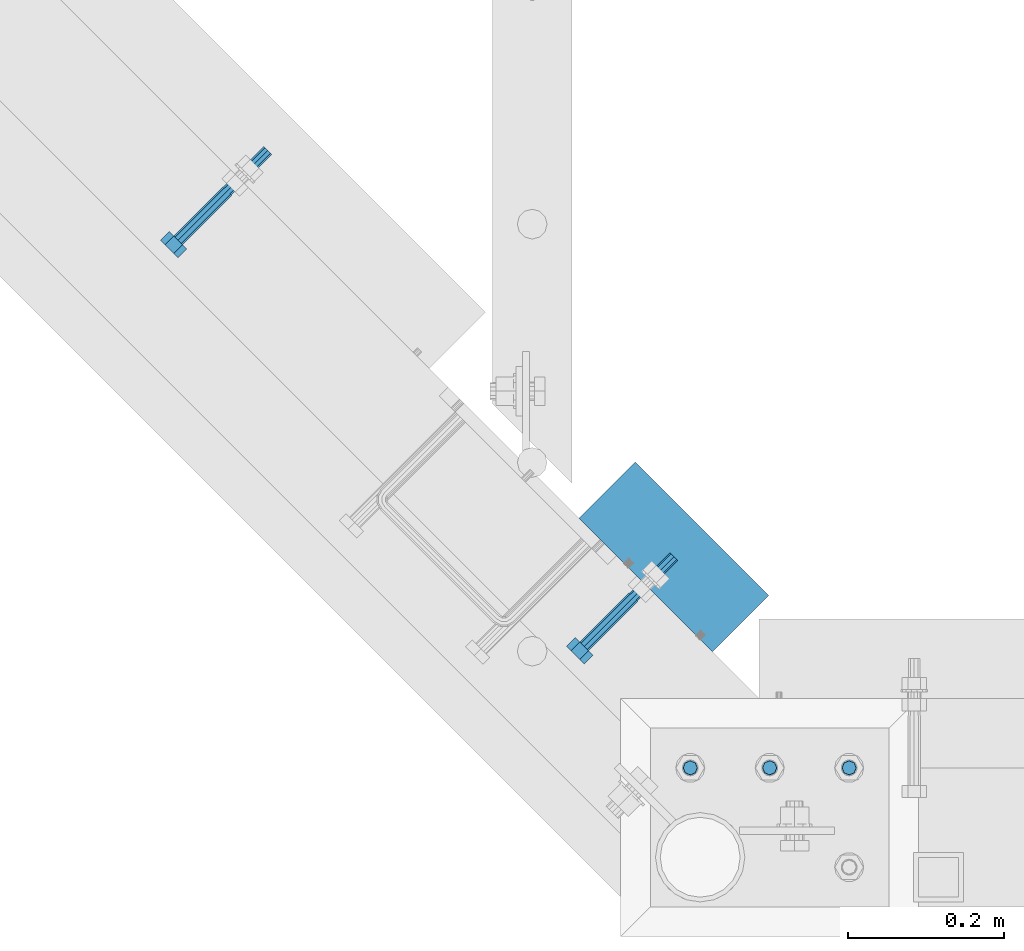
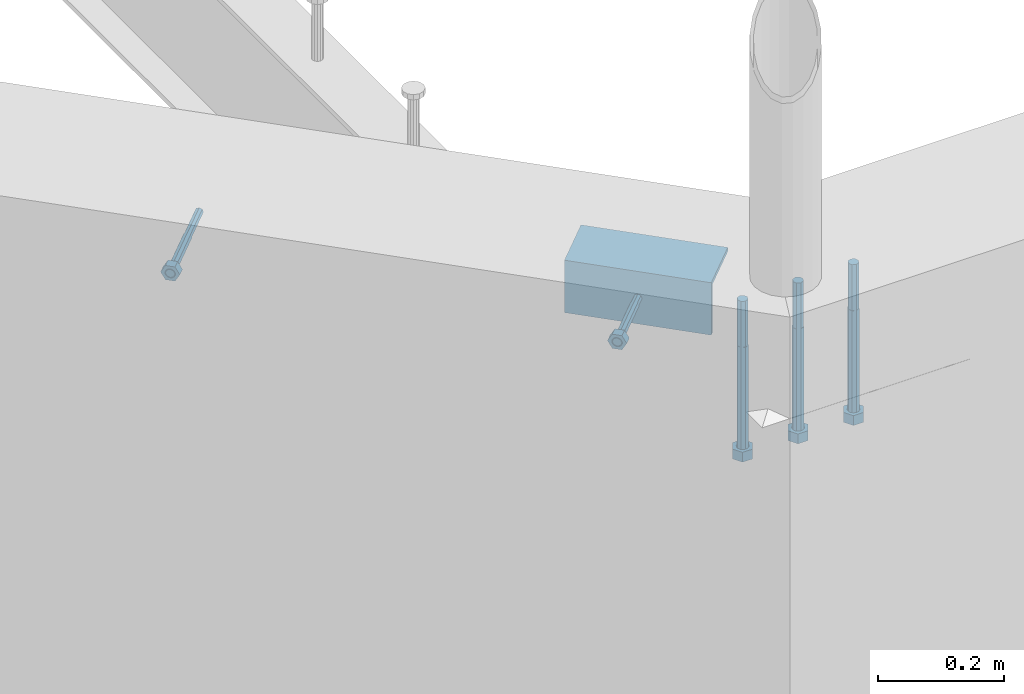
# One storey, part 382 of 975: 6 beams.
"""IFC2X3 building model written with IfcOpenShell, lengths in millimetres."""

from ifc_helpers import new_model, si_unit, frame, origin_with_axes, place, context, subcontext, project, spatial, faceted_brep, material, type_object, element, save


model = new_model("IFC2X3")

# Units and contexts
model_context = context("Model", 3, precision=1e-05, world=origin_with_axes())
body_context = subcontext(model_context, "Body", "Model", "MODEL_VIEW")
ifc_project = project(units=[si_unit("LENGTHUNIT", "METRE", prefix="MILLI"), si_unit("AREAUNIT", "SQUARE_METRE"), si_unit("VOLUMEUNIT", "CUBIC_METRE"), si_unit("MASSUNIT", "GRAM", prefix="KILO"), si_unit("TIMEUNIT", "SECOND"), si_unit("PLANEANGLEUNIT", "RADIAN"), si_unit("SOLIDANGLEUNIT", "STERADIAN"), si_unit("THERMODYNAMICTEMPERATUREUNIT", "DEGREE_CELSIUS"), si_unit("LUMINOUSINTENSITYUNIT", "LUMEN")], contexts=[model_context])

# Site, building, storey
site_placement = place(None, origin_with_axes())
site = spatial("IfcSite", under=ifc_project, at=site_placement, CompositionType="ELEMENT")
building_placement = place(site_placement, origin_with_axes())
building = spatial("IfcBuilding", under=site, at=building_placement, Name="Undefined", CompositionType="ELEMENT")
storey_placement = place(building_placement, origin_with_axes())
storey = spatial("IfcBuildingStorey", under=building, at=storey_placement, Name="Undefined", CompositionType="ELEMENT", Elevation=0.0)

# Beams
ifc_material_1 = material(Name="STEEL/F1554-36")
beam_type_1 = type_object("IfcBeamType", PredefinedType="NOTDEFINED")
beam_1_placement = place(storey_placement, frame((4419.9150254658, 434.231567113535, 3886.2), z_axis=(0.0, 0.0, -1.0), x_axis=(-0.707106781186548, -0.707106781186548, 0.0)))
element("IfcBeam", 1, at=beam_1_placement, inside=storey, type_object=beam_type_1, material=ifc_material_1, Name="HEADED_ANCHOR_BOLT", context=body_context, shape_type="Brep", body=[
    faceted_brep([(88.9000000184824, 7.94000001861696, -13.7499999799138), (88.8999999527368, 15.8800000758411, 2.00943759409711e-08), (104.774999952569, 15.8800001213949, 6.97191353538074e-08), (104.775000018315, 7.94000006417082, -13.7499999302891), (88.900000064019, -7.94000009583215, -13.7499999799147), (104.775000063852, -7.9400000502792, -13.74999993029), (88.9000000438027, -15.880000153059, 2.00925569515675e-08), (104.775000043643, -15.8800001075042, 6.9716406869702e-08), (88.8999999780608, -7.94000009583488, 13.7500000200998), (104.774999977893, -7.94000005028101, 13.7500000697237), (88.8999999325279, 7.94000001861514, 13.7500000201007), (104.774999932361, 7.940000064169, 13.7500000697246), (88.9000000119959, 3.78780480527439, -7.86545778426807), (88.8999999957159, 6.82538844544797, -5.4430656647246), (88.8999999799416, 8.51112018845743, -1.94260763148395), (88.8999999677944, 8.51112018845652, 1.94260767167179), (88.8999999616899, 6.82538844544615, 5.44306570491244), (88.8999999628249, 3.78780480527257, 7.86545782445592), (88.8999999709849, -3.86089595849626e-08, 8.72999956233434), (88.8999999845473, -3.7878048824914, 7.8654578244541), (88.9000000008309, -6.82538852266407, 5.44306570491153), (88.9000000166052, -8.51112026567444, 1.94260767166998), (88.9000000287488, -8.51112026567353, -1.94260763148577), (88.9000000348606, -6.82538852266407, -5.44306566472642), (88.9000000337182, -3.78780488248958, -7.86545778426898), (88.9000000255583, -3.86080500902608e-08, -8.72999952214832), (104.775000025395, 6.94581103743985e-09, -8.72999947252447), (104.775000011829, 3.78780485082825, -7.86545773464422), (104.774999995549, 6.82538849100092, -5.44306561510075), (104.774999979774, 8.51112023401038, -1.9426075818601), (104.774999967627, 8.51112023401038, 1.94260772129564), (104.774999961523, 6.82538849100092, 5.44306575453629), (104.774999962658, 3.78780485082643, 7.86545787407977), (104.774999970818, 6.94399204803631e-09, 8.7299996119591), (104.77499998438, -3.78780483693754, 7.86545787407886), (104.775000000664, -6.82538847711112, 5.44306575453538), (104.775000016438, -8.51112022012057, 1.94260772129473), (104.775000028581, -8.51112022012057, -1.94260758186101), (104.775000034693, -6.82538847711021, -5.44306561510166), (104.775000033551, -3.78780483693663, -7.86545773464422), (-2.99107341561466e-07, -5.61266007567065, 5.61266007566792), (-4.22995071858168e-07, -7.93750000000728, 0.0), (104.774999998088, -7.93749999999, -4.45652403868735e-11), (104.774999998088, -5.61266007565791, 5.61266007562426), (-1.09139364212751e-11, 1.81898940354586e-12, 7.9375), (104.774999998095, 1.18234311230481e-11, 7.93749999995816), (2.99089151667431e-07, 5.61266007567428, 5.61266007566792), (104.774999998102, 5.61266007568065, 5.61266007562517), (4.22980519942939e-07, 7.93750000001091, 0.0), (104.77499999811, 7.93750000001364, -4.36557456851006e-11), (2.99089151667431e-07, 5.61266007567428, -5.61266007566792), (104.774999998102, 5.61266007568156, -5.61266007571339), (-1.09139364212751e-11, 1.81898940354586e-12, -7.9375), (104.774999998099, 1.2732925824821e-11, -7.93750000004547), (-73.0249999592124, 5.05157065939329, -5.0515715445581), (-73.0249999269472, -1.85405951924622e-07, -7.14400069976364), (-73.0249999328516, -5.0515710302052, -5.05157154455992), (-73.0249999734697, -7.14400018541073, -6.9975976657588e-07), (-73.0250000250016, -5.05157103020611, 5.05157014504039), (-73.0250000572705, -1.85406861419324e-07, 7.1439993002441), (-73.0250000513661, 5.05157065939238, 5.05157014503948), (-73.025000010748, 7.14399981459792, -6.99758857081179e-07), (0.00625003290042514, 5.05157085007795, -5.05157087849238), (0.00625006516929716, 5.27870724909008e-09, -7.1440000336961), (0.00625005926485755, -5.05157083952145, -5.05157087849329), (0.00625001864682417, -7.14399999472516, -3.36940502165817e-08), (0.00624996711121639, -5.05157083952145, 5.05157081110519), (0.00624993484598235, 5.2777977543883e-09, 7.14399996631164), (0.00624994074678398, 5.05157085007704, 5.05157081110701), (0.00624998136845534, 7.14400000528167, -3.36922312271781e-08), (-2.99107341561466e-07, -5.61266007567065, -5.61266007566792), (104.774999998092, -5.612660075657, -5.6126600757143)], [[[0, 1, 2, 3]], [[4, 0, 3, 5]], [[6, 4, 5, 7]], [[8, 6, 7, 9]], [[10, 8, 9, 11]], [[0, 4, 6, 8, 10, 1], [12, 13, 14, 15, 16, 17, 18, 19, 20, 21, 22, 23, 24, 25]], [[12, 25, 26, 27]], [[13, 12, 27, 28]], [[14, 13, 28, 29]], [[15, 14, 29, 30]], [[16, 15, 30, 31]], [[17, 16, 31, 32]], [[18, 17, 32, 33]], [[19, 18, 33, 34]], [[20, 19, 34, 35]], [[21, 20, 35, 36]], [[22, 21, 36, 37]], [[23, 22, 37, 38]], [[24, 23, 38, 39]], [[25, 24, 39, 26]], [[9, 7, 5, 3, 2, 11], [38, 37, 36, 35, 34, 33, 32, 31, 30, 29, 28, 27, 26, 39]], [[1, 10, 11, 2]], [[40, 41, 42, 43]], [[44, 40, 43, 45]], [[46, 44, 45, 47]], [[48, 46, 47, 49]], [[50, 48, 49, 51]], [[52, 50, 51, 53]], [[54, 55, 56, 57, 58, 59, 60, 61]], [[55, 54, 62, 63]], [[56, 55, 63, 64]], [[57, 56, 64, 65]], [[58, 57, 65, 66]], [[59, 58, 66, 67]], [[60, 59, 67, 68]], [[61, 60, 68, 69]], [[54, 61, 69, 62]], [[40, 44, 46, 48, 50, 52, 70, 41], [68, 67, 66, 65, 64, 63, 62, 69]], [[41, 70, 71, 42]], [[53, 51, 49, 47, 45, 43, 42, 71]], [[70, 52, 53, 71]]]),
])
beam_2_placement = place(storey_placement, frame((3900.57704132325, 953.569551450239, 3886.2), z_axis=(0.0, 0.0, 1.0), x_axis=(-0.707106781186548, -0.707106781186548, 0.0)))
element("IfcBeam", 2, at=beam_2_placement, inside=storey, type_object=beam_type_1, material=ifc_material_1, Name="HEADED_ANCHOR_BOLT", context=body_context, shape_type="Brep", body=[
    faceted_brep([(88.9000000184824, 7.94000001861696, -13.7499999799138), (88.8999999527368, 15.8800000758411, 2.00943759409711e-08), (104.774999952569, 15.8800001213949, 6.97191353538074e-08), (104.775000018315, 7.94000006417082, -13.7499999302891), (88.900000064019, -7.94000009583215, -13.7499999799147), (104.775000063852, -7.9400000502792, -13.74999993029), (88.9000000438027, -15.880000153059, 2.00925569515675e-08), (104.775000043643, -15.8800001075042, 6.9716406869702e-08), (88.8999999780608, -7.94000009583488, 13.7500000200998), (104.774999977893, -7.94000005028101, 13.7500000697237), (88.8999999325279, 7.94000001861514, 13.7500000201007), (104.774999932361, 7.940000064169, 13.7500000697246), (88.9000000119959, 3.78780480527439, -7.86545778426807), (88.8999999957159, 6.82538844544797, -5.4430656647246), (88.8999999799416, 8.51112018845743, -1.94260763148395), (88.8999999677944, 8.51112018845652, 1.94260767167179), (88.8999999616899, 6.82538844544615, 5.44306570491244), (88.8999999628249, 3.78780480527257, 7.86545782445592), (88.8999999709849, -3.86089595849626e-08, 8.72999956233434), (88.8999999845473, -3.7878048824914, 7.8654578244541), (88.9000000008309, -6.82538852266407, 5.44306570491153), (88.9000000166052, -8.51112026567444, 1.94260767166998), (88.9000000287488, -8.51112026567353, -1.94260763148577), (88.9000000348606, -6.82538852266407, -5.44306566472642), (88.9000000337182, -3.78780488248958, -7.86545778426898), (88.9000000255583, -3.86080500902608e-08, -8.72999952214832), (104.775000025395, 6.94581103743985e-09, -8.72999947252447), (104.775000011829, 3.78780485082825, -7.86545773464422), (104.774999995549, 6.82538849100092, -5.44306561510075), (104.774999979774, 8.51112023401038, -1.9426075818601), (104.774999967627, 8.51112023401038, 1.94260772129564), (104.774999961523, 6.82538849100092, 5.44306575453629), (104.774999962658, 3.78780485082643, 7.86545787407977), (104.774999970818, 6.94399204803631e-09, 8.7299996119591), (104.77499998438, -3.78780483693754, 7.86545787407886), (104.775000000664, -6.82538847711112, 5.44306575453538), (104.775000016438, -8.51112022012057, 1.94260772129473), (104.775000028581, -8.51112022012057, -1.94260758186101), (104.775000034693, -6.82538847711021, -5.44306561510166), (104.775000033551, -3.78780483693663, -7.86545773464422), (-2.99107341561466e-07, -5.61266007567065, 5.61266007566792), (-4.22995071858168e-07, -7.93750000000728, 0.0), (104.774999998088, -7.93749999999, -4.45652403868735e-11), (104.774999998088, -5.61266007565791, 5.61266007562426), (-1.09139364212751e-11, 1.81898940354586e-12, 7.9375), (104.774999998095, 1.18234311230481e-11, 7.93749999995816), (2.99089151667431e-07, 5.61266007567428, 5.61266007566792), (104.774999998102, 5.61266007568065, 5.61266007562517), (4.22980519942939e-07, 7.93750000001091, 0.0), (104.77499999811, 7.93750000001364, -4.36557456851006e-11), (2.99089151667431e-07, 5.61266007567428, -5.61266007566792), (104.774999998102, 5.61266007568156, -5.61266007571339), (-1.09139364212751e-11, 1.81898940354586e-12, -7.9375), (104.774999998099, 1.2732925824821e-11, -7.93750000004547), (-73.0249999592124, 5.05157065939329, -5.0515715445581), (-73.0249999269472, -1.85405951924622e-07, -7.14400069976364), (-73.0249999328516, -5.0515710302052, -5.05157154455992), (-73.0249999734697, -7.14400018541073, -6.9975976657588e-07), (-73.0250000250016, -5.05157103020611, 5.05157014504039), (-73.0250000572705, -1.85406861419324e-07, 7.1439993002441), (-73.0250000513661, 5.05157065939238, 5.05157014503948), (-73.025000010748, 7.14399981459792, -6.99758857081179e-07), (0.00625003290042514, 5.05157085007795, -5.05157087849238), (0.00625006516929716, 5.27870724909008e-09, -7.1440000336961), (0.00625005926485755, -5.05157083952145, -5.05157087849329), (0.00625001864682417, -7.14399999472516, -3.36940502165817e-08), (0.00624996711121639, -5.05157083952145, 5.05157081110519), (0.00624993484598235, 5.2777977543883e-09, 7.14399996631164), (0.00624994074678398, 5.05157085007704, 5.05157081110701), (0.00624998136845534, 7.14400000528167, -3.36922312271781e-08), (-2.99107341561466e-07, -5.61266007567065, -5.61266007566792), (104.774999998092, -5.612660075657, -5.6126600757143)], [[[0, 1, 2, 3]], [[4, 0, 3, 5]], [[6, 4, 5, 7]], [[8, 6, 7, 9]], [[10, 8, 9, 11]], [[0, 4, 6, 8, 10, 1], [12, 13, 14, 15, 16, 17, 18, 19, 20, 21, 22, 23, 24, 25]], [[12, 25, 26, 27]], [[13, 12, 27, 28]], [[14, 13, 28, 29]], [[15, 14, 29, 30]], [[16, 15, 30, 31]], [[17, 16, 31, 32]], [[18, 17, 32, 33]], [[19, 18, 33, 34]], [[20, 19, 34, 35]], [[21, 20, 35, 36]], [[22, 21, 36, 37]], [[23, 22, 37, 38]], [[24, 23, 38, 39]], [[25, 24, 39, 26]], [[9, 7, 5, 3, 2, 11], [38, 37, 36, 35, 34, 33, 32, 31, 30, 29, 28, 27, 26, 39]], [[1, 10, 11, 2]], [[40, 41, 42, 43]], [[44, 40, 43, 45]], [[46, 44, 45, 47]], [[48, 46, 47, 49]], [[50, 48, 49, 51]], [[52, 50, 51, 53]], [[54, 55, 56, 57, 58, 59, 60, 61]], [[55, 54, 62, 63]], [[56, 55, 63, 64]], [[57, 56, 64, 65]], [[58, 57, 65, 66]], [[59, 58, 66, 67]], [[60, 59, 67, 68]], [[61, 60, 68, 69]], [[54, 61, 69, 62]], [[40, 44, 46, 48, 50, 52, 70, 41], [68, 67, 66, 65, 64, 63, 62, 69]], [[41, 70, 71, 42]], [[53, 51, 49, 47, 45, 43, 42, 71]], [[70, 52, 53, 71]]]),
])
ifc_material_2 = material(Name="STEEL/A36")
beam_type_2 = type_object("IfcBeamType", Name="L4X4X5/16", PredefinedType="NOTDEFINED")
beam_3_placement = place(storey_placement, frame((4386.18473903302, 571.23479905934, 3886.2), z_axis=(0.0, 0.0, -1.0), x_axis=(0.707106781186513, -0.707106781186582, 3.1377567211166e-14)))
element("IfcBeam", 3, at=beam_3_placement, inside=storey, type_object=beam_type_2, material=ifc_material_2, Name="LEDGER_ANGLE", ObjectType="L4X4X5/16", context=body_context, shape_type="Brep", body=[
    faceted_brep([(-1.90993887372315e-11, 50.8000000000002, -50.8), (2.00088834390044e-11, 50.8000000000002, 50.8), (241.453657242685, 50.8000000000306, 50.8000000000002), (241.453657242685, 50.8000000000306, -50.8000000000002), (2.00088834390044e-11, 42.8625000000002, 50.8), (241.453657242687, 42.8625000000288, 50.8000000000002), (-1.63709046319127e-11, 42.8625000000002, -42.8625), (241.453657242687, 42.8625000000288, -42.8625000000002), (-1.63709046319127e-11, -50.8000000000002, -42.8625), (241.453657242709, -50.7999999999952, -42.8625000000002), (-1.90993887372315e-11, -50.8000000000002, -50.8), (241.453657242709, -50.7999999999952, -50.8000000000002)], [[[0, 1, 2, 3]], [[1, 4, 5, 2]], [[4, 6, 7, 5]], [[6, 8, 9, 7]], [[8, 10, 11, 9]], [[10, 0, 3, 11]], [[5, 7, 9, 11, 3, 2]], [[10, 8, 6, 4, 1, 0]]]),
])
beam_type_3 = type_object("IfcBeamType", PredefinedType="NOTDEFINED")
beam_4_placement = place(storey_placement, frame((4594.22499721142, 215.8999986637, 3917.95), z_axis=(0.0, 1.0, 0.0), x_axis=(0.0, 0.0, -1.0)))
element("IfcBeam", 4, at=beam_4_placement, inside=storey, type_object=beam_type_3, material=ifc_material_1, Name="HEADED_BOLT", context=body_context, shape_type="Brep", body=[
    faceted_brep([(196.84375, -9.12999965559902, 15.8099993757314), (196.84375, -18.2599997700399, -1.0438852768857e-06), (215.893749999999, -18.2599997700399, -1.0438852768857e-06), (215.893749999999, -9.12999965559902, 15.8099993757314), (196.84375, 9.13000057328281, 15.8099993757314), (215.893749999999, 9.13000057328281, 15.8099993757314), (196.84375, 18.2600006877237, -1.0438852768857e-06), (215.893749999999, 18.2600006877237, -1.0438852768857e-06), (196.84375, 9.13000057328281, -15.810001463502), (215.893749999999, 9.13000057328281, -15.810001463502), (196.84375, -9.12999965559902, -15.810001463502), (215.893749999999, -9.12999965559902, -15.810001463502), (196.84375, -4.47767959644079, 9.2979973979138), (196.84375, -8.06850020163256, 6.43441352102286), (196.84375, -10.0612552973498, 2.29641492663589), (196.84375, -10.0612552973498, -2.29641701440644), (196.84375, -8.06850020163256, -6.43441560879344), (196.84375, -4.47767959644079, -9.29799948568439), (196.84375, 4.58841896033846e-07, -10.3200007387095), (196.84375, 4.47768051412459, -9.29799948568436), (196.84375, 8.06850111931635, -6.43441560879342), (196.84375, 10.0612562150336, -2.29641701440644), (196.84375, 10.0612562150336, 2.29641492663589), (196.84375, 8.06850111931635, 6.43441352102289), (196.84375, 4.47768051412459, 9.29799739791383), (196.84375, 4.58841896033846e-07, 10.3199986509389), (215.893749999999, 4.58841896033846e-07, 10.3199986509389), (215.893749999999, -4.47767959644079, 9.2979973979138), (215.893749999999, -8.06850020163256, 6.43441352102286), (215.893749999999, -10.0612552973498, 2.29641492663589), (215.893749999999, -10.0612552973498, -2.29641701440644), (215.893749999999, -8.06850020163256, -6.43441560879344), (215.893749999999, -4.47767959644079, -9.29799948568439), (215.893749999999, 4.58841896033846e-07, -10.3200007387095), (215.893749999999, 4.47768051412459, -9.29799948568436), (215.893749999999, 8.06850111931635, -6.43441560879342), (215.893749999999, 10.0612562150336, -2.29641701440644), (215.893749999999, 10.0612562150336, 2.29641492663589), (215.893749999999, 8.06850111931635, 6.43441352102289), (215.893749999999, 4.47768051412459, 9.29799739791383), (0.0, -6.73519209080223, 6.73519209080186), (0.0, -9.52499999999964, 0.0), (215.900000000001, -9.52499999999964, 0.0), (215.900000000001, -6.73519209080223, 6.73519209080186), (-9.87109982941227e-13, -1.20792265079217e-13, 9.52499961853027), (215.900000000001, 0.0, 9.52500000000001), (0.0, 6.73519209080223, 6.73519209080186), (215.900000000001, 6.73519209080223, 6.73519209080186), (0.0, 9.52499999999964, 0.0), (215.900000000001, 9.52499999999964, 0.0), (0.0, 6.73519209080223, -6.73519209080186), (215.900000000001, 6.73519209080223, -6.73519209080186), (2.95075507493764e-12, -1.20792265079217e-13, -9.52499961853027), (215.900000000001, 0.0, -9.52500000000001), (-88.9444446471748, -6.3639605718372, 6.39952908988423), (-88.9433906823501, 4.58841896033846e-07, 9.03556784850662), (-88.9444446471748, 6.36396148952099, 6.39952908988423), (-88.9469891433491, 9.0000004588419, 0.0355685678769078), (-88.9495336395235, 6.36396148952099, -6.32839195413041), (-88.9505876043481, 4.58841896033846e-07, -8.9644307127528), (-88.9495336395235, -6.3639605718372, -6.32839195413041), (-88.9469891433491, -8.9999995411581, 0.0355685678769078), (0.0124298302243915, 6.36396148952099, -6.36396152997716), (0.0113758653997138, 4.58841896033846e-07, -9.00000028859955), (0.0124298302243915, -6.3639605718372, -6.36396152997716), (0.0149743263987148, -8.9999995411581, -1.00796984270346e-06), (0.0175188225730381, -6.3639605718372, 6.36395951403748), (0.0185727873977157, 4.58841896033846e-07, 8.99999827265987), (0.0175188225730381, 6.36396148952099, 6.36395951403748), (0.0149743263987148, 9.0000004588419, -1.00796984270346e-06), (0.0, -6.73519209080223, -6.73519209080186), (215.900000000001, -6.73519209080223, -6.73519209080186)], [[[0, 1, 2, 3]], [[4, 0, 3, 5]], [[6, 4, 5, 7]], [[8, 6, 7, 9]], [[10, 8, 9, 11]], [[0, 4, 6, 8, 10, 1], [12, 13, 14, 15, 16, 17, 18, 19, 20, 21, 22, 23, 24, 25]], [[12, 25, 26, 27]], [[13, 12, 27, 28]], [[14, 13, 28, 29]], [[15, 14, 29, 30]], [[16, 15, 30, 31]], [[17, 16, 31, 32]], [[18, 17, 32, 33]], [[19, 18, 33, 34]], [[20, 19, 34, 35]], [[21, 20, 35, 36]], [[22, 21, 36, 37]], [[23, 22, 37, 38]], [[24, 23, 38, 39]], [[25, 24, 39, 26]], [[9, 7, 5, 3, 2, 11], [38, 37, 36, 35, 34, 33, 32, 31, 30, 29, 28, 27, 26, 39]], [[1, 10, 11, 2]], [[40, 41, 42, 43]], [[44, 40, 43, 45]], [[46, 44, 45, 47]], [[48, 46, 47, 49]], [[50, 48, 49, 51]], [[52, 50, 51, 53]], [[54, 55, 56, 57, 58, 59, 60, 61]], [[59, 58, 62, 63]], [[60, 59, 63, 64]], [[61, 60, 64, 65]], [[54, 61, 65, 66]], [[55, 54, 66, 67]], [[56, 55, 67, 68]], [[57, 56, 68, 69]], [[58, 57, 69, 62]], [[40, 44, 46, 48, 50, 52, 70, 41], [68, 67, 66, 65, 64, 63, 62, 69]], [[41, 70, 71, 42]], [[53, 51, 49, 47, 45, 43, 42, 71]], [[70, 52, 53, 71]]]),
])
beam_5_placement = place(storey_placement, frame((4492.62500038641, 215.900001391127, 3917.95), z_axis=(0.0, 1.0, 0.0), x_axis=(0.0, 0.0, -1.0)))
element("IfcBeam", 5, at=beam_5_placement, inside=storey, type_object=beam_type_3, material=ifc_material_1, Name="HEADED_BOLT", context=body_context, shape_type="Brep", body=[
    faceted_brep([(196.84375, -9.12999965559902, 15.8099993757314), (196.84375, -18.2599997700399, -1.0438852768857e-06), (215.893749999999, -18.2599997700399, -1.0438852768857e-06), (215.893749999999, -9.12999965559902, 15.8099993757314), (196.84375, 9.13000057328281, 15.8099993757314), (215.893749999999, 9.13000057328281, 15.8099993757314), (196.84375, 18.2600006877237, -1.0438852768857e-06), (215.893749999999, 18.2600006877237, -1.0438852768857e-06), (196.84375, 9.13000057328281, -15.810001463502), (215.893749999999, 9.13000057328281, -15.810001463502), (196.84375, -9.12999965559902, -15.810001463502), (215.893749999999, -9.12999965559902, -15.810001463502), (196.84375, -4.47767959644079, 9.2979973979138), (196.84375, -8.06850020163256, 6.43441352102286), (196.84375, -10.0612552973498, 2.29641492663589), (196.84375, -10.0612552973498, -2.29641701440644), (196.84375, -8.06850020163256, -6.43441560879344), (196.84375, -4.47767959644079, -9.29799948568439), (196.84375, 4.58841896033846e-07, -10.3200007387095), (196.84375, 4.47768051412459, -9.29799948568436), (196.84375, 8.06850111931635, -6.43441560879342), (196.84375, 10.0612562150336, -2.29641701440644), (196.84375, 10.0612562150336, 2.29641492663589), (196.84375, 8.06850111931635, 6.43441352102289), (196.84375, 4.47768051412459, 9.29799739791383), (196.84375, 4.58841896033846e-07, 10.3199986509389), (215.893749999999, 4.58841896033846e-07, 10.3199986509389), (215.893749999999, -4.47767959644079, 9.2979973979138), (215.893749999999, -8.06850020163256, 6.43441352102286), (215.893749999999, -10.0612552973498, 2.29641492663589), (215.893749999999, -10.0612552973498, -2.29641701440644), (215.893749999999, -8.06850020163256, -6.43441560879344), (215.893749999999, -4.47767959644079, -9.29799948568439), (215.893749999999, 4.58841896033846e-07, -10.3200007387095), (215.893749999999, 4.47768051412459, -9.29799948568436), (215.893749999999, 8.06850111931635, -6.43441560879342), (215.893749999999, 10.0612562150336, -2.29641701440644), (215.893749999999, 10.0612562150336, 2.29641492663589), (215.893749999999, 8.06850111931635, 6.43441352102289), (215.893749999999, 4.47768051412459, 9.29799739791383), (0.0, -6.73519209080223, 6.73519209080186), (0.0, -9.52499999999964, 0.0), (215.900000000001, -9.52499999999964, 0.0), (215.900000000001, -6.73519209080223, 6.73519209080186), (-9.87109982941227e-13, -1.20792265079217e-13, 9.52499961853027), (215.900000000001, 0.0, 9.52500000000001), (0.0, 6.73519209080223, 6.73519209080186), (215.900000000001, 6.73519209080223, 6.73519209080186), (0.0, 9.52499999999964, 0.0), (215.900000000001, 9.52499999999964, 0.0), (0.0, 6.73519209080223, -6.73519209080186), (215.900000000001, 6.73519209080223, -6.73519209080186), (2.95075507493764e-12, -1.20792265079217e-13, -9.52499961853027), (215.900000000001, 0.0, -9.52500000000001), (-88.9444446471748, -6.3639605718372, 6.39952908988423), (-88.9433906823501, 4.58841896033846e-07, 9.03556784850662), (-88.9444446471748, 6.36396148952099, 6.39952908988423), (-88.9469891433491, 9.0000004588419, 0.0355685678769078), (-88.9495336395235, 6.36396148952099, -6.32839195413041), (-88.9505876043481, 4.58841896033846e-07, -8.9644307127528), (-88.9495336395235, -6.3639605718372, -6.32839195413041), (-88.9469891433491, -8.9999995411581, 0.0355685678769078), (0.0124298302243915, 6.36396148952099, -6.36396152997716), (0.0113758653997138, 4.58841896033846e-07, -9.00000028859955), (0.0124298302243915, -6.3639605718372, -6.36396152997716), (0.0149743263987148, -8.9999995411581, -1.00796984270346e-06), (0.0175188225730381, -6.3639605718372, 6.36395951403748), (0.0185727873977157, 4.58841896033846e-07, 8.99999827265987), (0.0175188225730381, 6.36396148952099, 6.36395951403748), (0.0149743263987148, 9.0000004588419, -1.00796984270346e-06), (0.0, -6.73519209080223, -6.73519209080186), (215.900000000001, -6.73519209080223, -6.73519209080186)], [[[0, 1, 2, 3]], [[4, 0, 3, 5]], [[6, 4, 5, 7]], [[8, 6, 7, 9]], [[10, 8, 9, 11]], [[0, 4, 6, 8, 10, 1], [12, 13, 14, 15, 16, 17, 18, 19, 20, 21, 22, 23, 24, 25]], [[12, 25, 26, 27]], [[13, 12, 27, 28]], [[14, 13, 28, 29]], [[15, 14, 29, 30]], [[16, 15, 30, 31]], [[17, 16, 31, 32]], [[18, 17, 32, 33]], [[19, 18, 33, 34]], [[20, 19, 34, 35]], [[21, 20, 35, 36]], [[22, 21, 36, 37]], [[23, 22, 37, 38]], [[24, 23, 38, 39]], [[25, 24, 39, 26]], [[9, 7, 5, 3, 2, 11], [38, 37, 36, 35, 34, 33, 32, 31, 30, 29, 28, 27, 26, 39]], [[1, 10, 11, 2]], [[40, 41, 42, 43]], [[44, 40, 43, 45]], [[46, 44, 45, 47]], [[48, 46, 47, 49]], [[50, 48, 49, 51]], [[52, 50, 51, 53]], [[54, 55, 56, 57, 58, 59, 60, 61]], [[59, 58, 62, 63]], [[60, 59, 63, 64]], [[61, 60, 64, 65]], [[54, 61, 65, 66]], [[55, 54, 66, 67]], [[56, 55, 67, 68]], [[57, 56, 68, 69]], [[58, 57, 69, 62]], [[40, 44, 46, 48, 50, 52, 70, 41], [68, 67, 66, 65, 64, 63, 62, 69]], [[41, 70, 71, 42]], [[53, 51, 49, 47, 45, 43, 42, 71]], [[70, 52, 53, 71]]]),
])
beam_6_placement = place(storey_placement, frame((4695.82500038642, 215.9000012037, 3917.95), z_axis=(0.0, 1.0, 0.0), x_axis=(0.0, 0.0, -1.0)))
element("IfcBeam", 6, at=beam_6_placement, inside=storey, type_object=beam_type_3, material=ifc_material_1, Name="HEADED_BOLT", context=body_context, shape_type="Brep", body=[
    faceted_brep([(196.84375, -9.12999965559902, 15.8099993757314), (196.84375, -18.2599997700399, -1.0438852768857e-06), (215.893749999999, -18.2599997700399, -1.0438852768857e-06), (215.893749999999, -9.12999965559902, 15.8099993757314), (196.84375, 9.13000057328281, 15.8099993757314), (215.893749999999, 9.13000057328281, 15.8099993757314), (196.84375, 18.2600006877237, -1.0438852768857e-06), (215.893749999999, 18.2600006877237, -1.0438852768857e-06), (196.84375, 9.13000057328281, -15.810001463502), (215.893749999999, 9.13000057328281, -15.810001463502), (196.84375, -9.12999965559902, -15.810001463502), (215.893749999999, -9.12999965559902, -15.810001463502), (196.84375, -4.47767959644079, 9.2979973979138), (196.84375, -8.06850020163256, 6.43441352102286), (196.84375, -10.0612552973498, 2.29641492663589), (196.84375, -10.0612552973498, -2.29641701440644), (196.84375, -8.06850020163256, -6.43441560879344), (196.84375, -4.47767959644079, -9.29799948568439), (196.84375, 4.58841896033846e-07, -10.3200007387095), (196.84375, 4.47768051412459, -9.29799948568436), (196.84375, 8.06850111931635, -6.43441560879342), (196.84375, 10.0612562150336, -2.29641701440644), (196.84375, 10.0612562150336, 2.29641492663589), (196.84375, 8.06850111931635, 6.43441352102289), (196.84375, 4.47768051412459, 9.29799739791383), (196.84375, 4.58841896033846e-07, 10.3199986509389), (215.893749999999, 4.58841896033846e-07, 10.3199986509389), (215.893749999999, -4.47767959644079, 9.2979973979138), (215.893749999999, -8.06850020163256, 6.43441352102286), (215.893749999999, -10.0612552973498, 2.29641492663589), (215.893749999999, -10.0612552973498, -2.29641701440644), (215.893749999999, -8.06850020163256, -6.43441560879344), (215.893749999999, -4.47767959644079, -9.29799948568439), (215.893749999999, 4.58841896033846e-07, -10.3200007387095), (215.893749999999, 4.47768051412459, -9.29799948568436), (215.893749999999, 8.06850111931635, -6.43441560879342), (215.893749999999, 10.0612562150336, -2.29641701440644), (215.893749999999, 10.0612562150336, 2.29641492663589), (215.893749999999, 8.06850111931635, 6.43441352102289), (215.893749999999, 4.47768051412459, 9.29799739791383), (0.0, -6.73519209080223, 6.73519209080186), (0.0, -9.52499999999964, 0.0), (215.900000000001, -9.52499999999964, 0.0), (215.900000000001, -6.73519209080223, 6.73519209080186), (-9.87109982941227e-13, -1.20792265079217e-13, 9.52499961853027), (215.900000000001, 0.0, 9.52500000000001), (0.0, 6.73519209080223, 6.73519209080186), (215.900000000001, 6.73519209080223, 6.73519209080186), (0.0, 9.52499999999964, 0.0), (215.900000000001, 9.52499999999964, 0.0), (0.0, 6.73519209080223, -6.73519209080186), (215.900000000001, 6.73519209080223, -6.73519209080186), (2.95075507493764e-12, -1.20792265079217e-13, -9.52499961853027), (215.900000000001, 0.0, -9.52500000000001), (-88.9444446471748, -6.3639605718372, 6.39952908988423), (-88.9433906823501, 4.58841896033846e-07, 9.03556784850662), (-88.9444446471748, 6.36396148952099, 6.39952908988423), (-88.9469891433491, 9.0000004588419, 0.0355685678769078), (-88.9495336395235, 6.36396148952099, -6.32839195413041), (-88.9505876043481, 4.58841896033846e-07, -8.9644307127528), (-88.9495336395235, -6.3639605718372, -6.32839195413041), (-88.9469891433491, -8.9999995411581, 0.0355685678769078), (0.0124298302243915, 6.36396148952099, -6.36396152997716), (0.0113758653997138, 4.58841896033846e-07, -9.00000028859955), (0.0124298302243915, -6.3639605718372, -6.36396152997716), (0.0149743263987148, -8.9999995411581, -1.00796984270346e-06), (0.0175188225730381, -6.3639605718372, 6.36395951403748), (0.0185727873977157, 4.58841896033846e-07, 8.99999827265987), (0.0175188225730381, 6.36396148952099, 6.36395951403748), (0.0149743263987148, 9.0000004588419, -1.00796984270346e-06), (0.0, -6.73519209080223, -6.73519209080186), (215.900000000001, -6.73519209080223, -6.73519209080186)], [[[0, 1, 2, 3]], [[4, 0, 3, 5]], [[6, 4, 5, 7]], [[8, 6, 7, 9]], [[10, 8, 9, 11]], [[0, 4, 6, 8, 10, 1], [12, 13, 14, 15, 16, 17, 18, 19, 20, 21, 22, 23, 24, 25]], [[12, 25, 26, 27]], [[13, 12, 27, 28]], [[14, 13, 28, 29]], [[15, 14, 29, 30]], [[16, 15, 30, 31]], [[17, 16, 31, 32]], [[18, 17, 32, 33]], [[19, 18, 33, 34]], [[20, 19, 34, 35]], [[21, 20, 35, 36]], [[22, 21, 36, 37]], [[23, 22, 37, 38]], [[24, 23, 38, 39]], [[25, 24, 39, 26]], [[9, 7, 5, 3, 2, 11], [38, 37, 36, 35, 34, 33, 32, 31, 30, 29, 28, 27, 26, 39]], [[1, 10, 11, 2]], [[40, 41, 42, 43]], [[44, 40, 43, 45]], [[46, 44, 45, 47]], [[48, 46, 47, 49]], [[50, 48, 49, 51]], [[52, 50, 51, 53]], [[54, 55, 56, 57, 58, 59, 60, 61]], [[59, 58, 62, 63]], [[60, 59, 63, 64]], [[61, 60, 64, 65]], [[54, 61, 65, 66]], [[55, 54, 66, 67]], [[56, 55, 67, 68]], [[57, 56, 68, 69]], [[58, 57, 69, 62]], [[40, 44, 46, 48, 50, 52, 70, 41], [68, 67, 66, 65, 64, 63, 62, 69]], [[41, 70, 71, 42]], [[53, 51, 49, 47, 45, 43, 42, 71]], [[70, 52, 53, 71]]]),
])

save(model, "model.ifc")
